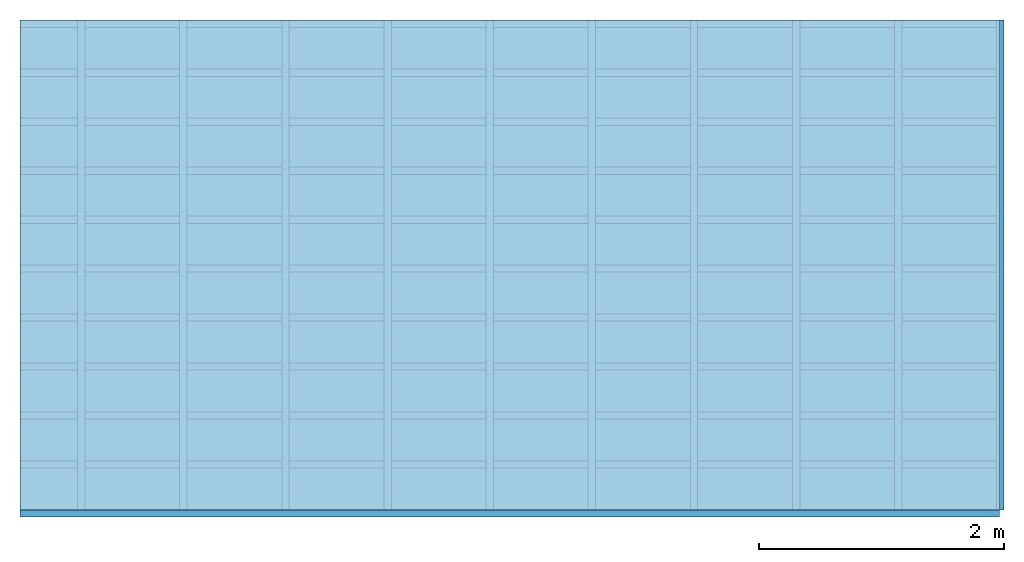
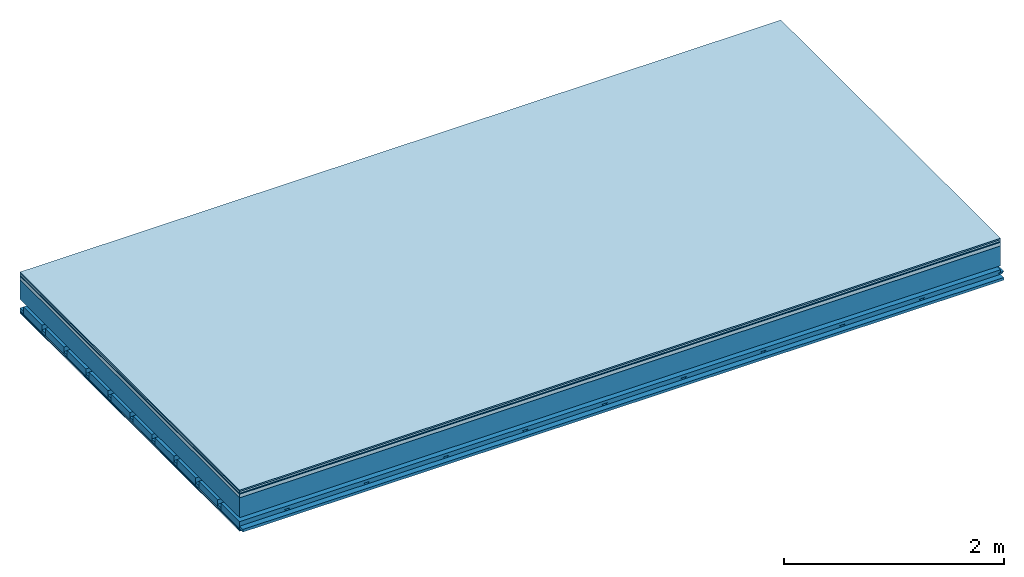
# One storey: 7 plates, 4 members, 1 element without a shape of its own.
"""IFC4 building model written with IfcOpenShell, lengths in metres."""

from ifc_helpers import new_model, si_unit, derived_unit, direction, frame, frame_2d, origin, origin_with_axes, place, context, project, spatial, polyline, rectangle, outline, extrude, material, layer, layer_set, type_object, element, aggregate, save


model = new_model("IFC4")

# Units and contexts
plan_context = context("Plan", 3, precision=1e-05, world=origin(), true_north=direction((0.0, 1.0)))
model_context = context("Model", 3, precision=1e-05, world=origin(), true_north=direction((0.0, 1.0)))
ifc_project = project(units=[si_unit("LENGTHUNIT", "METRE"), derived_unit("SOUNDPRESSUREUNIT", [(si_unit("PRESSUREUNIT", "PASCAL", prefix="MICRO"), 0)]), si_unit("ENERGYUNIT", "JOULE", prefix="MEGA"), si_unit("MASSUNIT", "GRAM", prefix="KILO"), derived_unit("THERMALTRANSMITTANCEUNIT", [(si_unit("POWERUNIT", "WATT"), 1), (si_unit("AREAUNIT", "SQUARE_METRE"), -1), (si_unit("THERMODYNAMICTEMPERATUREUNIT", "KELVIN"), -1)]), derived_unit("AREADENSITYUNIT", [(si_unit("MASSUNIT", "GRAM", prefix="KILO"), 1), (si_unit("AREAUNIT", "SQUARE_METRE"), -1)]), derived_unit("USERDEFINED", [(si_unit("ENERGYUNIT", "JOULE", prefix="MEGA"), 1), (si_unit("AREAUNIT", "SQUARE_METRE"), -1)])], contexts=[plan_context, model_context])

# Site, building, storey
site = spatial("IfcSite", under=ifc_project)
building_placement = place(None, origin())
building = spatial("IfcBuilding", under=site, at=building_placement)
storey_placement = place(building_placement, origin())
storey = spatial("IfcBuildingStorey", under=building, at=storey_placement)

# Slab, members, plates
ifc_material_1 = material(Category="11.013")
ifc_layer_1 = layer(ifc_material_1, 0.015, Name="Flooring")
ifc_material_2 = material(Category="03.007")
ifc_layer_2 = layer(ifc_material_2, 0.02, Name="On-material")
ifc_material_3 = material(Name="Wood fiber generic product", Category="10.009")
ifc_layer_3 = layer(ifc_material_3, 0.01, Name="Impact sound insulation")
ifc_material_4 = material(Name="Concrete panels", Category="02.007")
ifc_layer_4 = layer(ifc_material_4, 0.04, Name="on Supporting structure")
ifc_material_5 = material(Name="no composite action")
ifc_layer_5 = layer(ifc_material_5, 0.0, Name="Bond")
ifc_layer_6 = layer(None, 0.22, Name="Supporting structure")
ifc_layer_7 = layer(ifc_material_5, 0.0, Name="Bond")
ifc_layer_8 = layer(None, 0.095, Name="Coupling")
ifc_layer_9 = layer(None, 0.03, Name="Battens / profiles")
ifc_material_6 = material(Name="Plasterboard type A", Category="03.008")
ifc_layer_10 = layer(ifc_material_6, 0.0125, Name="Ceiling covering 1st layer")
ifc_layer_11 = layer(ifc_material_6, 0.0125, Name="Ceiling covering layer 2")
ifc_material_7 = material(Category="04.001")
ifc_layer_12 = layer(ifc_material_7, 0.003, Name="Surface / treatment")
ifc_layer_set = layer_set([ifc_layer_1, ifc_layer_2, ifc_layer_3, ifc_layer_4, ifc_layer_5, ifc_layer_6, ifc_layer_7, ifc_layer_8, ifc_layer_9, ifc_layer_10, ifc_layer_11, ifc_layer_12])
slab_type = type_object("IfcSlabType", Name="A2137", PredefinedType="NOTDEFINED", material=ifc_layer_set)
slab_placement = place(None, frame((0.0, 0.0, 0.0), z_axis=(0.0, 0.0, -1.0), x_axis=(1.0, 0.0, 0.0)))
slab = element("IfcSlab", 1, at=slab_placement, inside=storey, type_object=slab_type, material=ifc_layer_set, Name="Slab #1")
ifc_material_8 = material(Name="Solid timber panel")
member_1_placement = place(slab_placement, origin())
member_1 = element("IfcMember", 2, at=member_1_placement, material=ifc_material_8, Name="Supporting structure", context=plan_context, shape_type="SweptSolid", body=[
    extrude(rectangle(XDim=1.0, YDim=0.22, at=frame_2d((0.5, 0.11), x_axis=(1.0, 0.0))), frame((0.0, 4.0, 0.085), z_axis=(0.0, -1.0, 0.0), x_axis=(1.0, 0.0, 0.0)), (0.0, 0.0, 1.0), 4.0),
    extrude(rectangle(XDim=1.0, YDim=0.22, at=frame_2d((0.5, 0.11), x_axis=(1.0, 0.0))), frame((1.0, 4.0, 0.085), z_axis=(0.0, -1.0, 0.0), x_axis=(1.0, 0.0, 0.0)), (0.0, 0.0, 1.0), 4.0),
    extrude(rectangle(XDim=1.0, YDim=0.22, at=frame_2d((0.5, 0.11), x_axis=(1.0, 0.0))), frame((2.0, 4.0, 0.085), z_axis=(0.0, -1.0, 0.0), x_axis=(1.0, 0.0, 0.0)), (0.0, 0.0, 1.0), 4.0),
    extrude(rectangle(XDim=1.0, YDim=0.22, at=frame_2d((0.5, 0.11), x_axis=(1.0, 0.0))), frame((3.0, 4.0, 0.085), z_axis=(0.0, -1.0, 0.0), x_axis=(1.0, 0.0, 0.0)), (0.0, 0.0, 1.0), 4.0),
    extrude(rectangle(XDim=1.0, YDim=0.22, at=frame_2d((0.5, 0.11), x_axis=(1.0, 0.0))), frame((4.0, 4.0, 0.085), z_axis=(0.0, -1.0, 0.0), x_axis=(1.0, 0.0, 0.0)), (0.0, 0.0, 1.0), 4.0),
    extrude(rectangle(XDim=1.0, YDim=0.22, at=frame_2d((0.5, 0.11), x_axis=(1.0, 0.0))), frame((5.0, 4.0, 0.085), z_axis=(0.0, -1.0, 0.0), x_axis=(1.0, 0.0, 0.0)), (0.0, 0.0, 1.0), 4.0),
    extrude(rectangle(XDim=1.0, YDim=0.22, at=frame_2d((0.5, 0.11), x_axis=(1.0, 0.0))), frame((6.0, 4.0, 0.085), z_axis=(0.0, -1.0, 0.0), x_axis=(1.0, 0.0, 0.0)), (0.0, 0.0, 1.0), 4.0),
    extrude(rectangle(XDim=1.0, YDim=0.22, at=frame_2d((0.5, 0.11), x_axis=(1.0, 0.0))), frame((7.0, 4.0, 0.085), z_axis=(0.0, -1.0, 0.0), x_axis=(1.0, 0.0, 0.0)), (0.0, 0.0, 1.0), 4.0),
])
ifc_material_9 = material()
member_2_placement = place(slab_placement, origin())
member_2 = element("IfcMember", 3, at=member_2_placement, material=ifc_material_9, Name="Coupling", context=plan_context, shape_type="SweptSolid", body=[
    extrude(outline(polyline([(0.0, 0.0), (0.06, 0.0), (0.04, 0.02), (0.02, 0.02), (0.0, 0.0)])), frame((0.47, 4.0, 0.38), z_axis=(0.0, -1.0, 0.0), x_axis=(1.0, 0.0, 0.0)), (0.0, 0.0, 1.0), 4.0),
    extrude(outline(polyline([(0.0, 0.0), (0.06, 0.0), (0.04, 0.02), (0.02, 0.02), (0.0, 0.0)])), frame((1.304, 4.0, 0.38), z_axis=(0.0, -1.0, 0.0), x_axis=(1.0, 0.0, 0.0)), (0.0, 0.0, 1.0), 4.0),
    extrude(outline(polyline([(0.0, 0.0), (0.06, 0.0), (0.04, 0.02), (0.02, 0.02), (0.0, 0.0)])), frame((2.138, 4.0, 0.38), z_axis=(0.0, -1.0, 0.0), x_axis=(1.0, 0.0, 0.0)), (0.0, 0.0, 1.0), 4.0),
    extrude(outline(polyline([(0.0, 0.0), (0.06, 0.0), (0.04, 0.02), (0.02, 0.02), (0.0, 0.0)])), frame((2.972, 4.0, 0.38), z_axis=(0.0, -1.0, 0.0), x_axis=(1.0, 0.0, 0.0)), (0.0, 0.0, 1.0), 4.0),
    extrude(outline(polyline([(0.0, 0.0), (0.06, 0.0), (0.04, 0.02), (0.02, 0.02), (0.0, 0.0)])), frame((3.806, 4.0, 0.38), z_axis=(0.0, -1.0, 0.0), x_axis=(1.0, 0.0, 0.0)), (0.0, 0.0, 1.0), 4.0),
    extrude(outline(polyline([(0.0, 0.0), (0.06, 0.0), (0.04, 0.02), (0.02, 0.02), (0.0, 0.0)])), frame((4.64, 4.0, 0.38), z_axis=(0.0, -1.0, 0.0), x_axis=(1.0, 0.0, 0.0)), (0.0, 0.0, 1.0), 4.0),
    extrude(outline(polyline([(0.0, 0.0), (0.06, 0.0), (0.04, 0.02), (0.02, 0.02), (0.0, 0.0)])), frame((5.474, 4.0, 0.38), z_axis=(0.0, -1.0, 0.0), x_axis=(1.0, 0.0, 0.0)), (0.0, 0.0, 1.0), 4.0),
    extrude(outline(polyline([(0.0, 0.0), (0.06, 0.0), (0.04, 0.02), (0.02, 0.02), (0.0, 0.0)])), frame((6.308, 4.0, 0.38), z_axis=(0.0, -1.0, 0.0), x_axis=(1.0, 0.0, 0.0)), (0.0, 0.0, 1.0), 4.0),
    extrude(outline(polyline([(0.0, 0.0), (0.06, 0.0), (0.04, 0.02), (0.02, 0.02), (0.0, 0.0)])), frame((7.142, 4.0, 0.38), z_axis=(0.0, -1.0, 0.0), x_axis=(1.0, 0.0, 0.0)), (0.0, 0.0, 1.0), 4.0),
    extrude(outline(polyline([(0.0, 0.0), (0.06, 0.0), (0.04, 0.02), (0.02, 0.02), (0.0, 0.0)])), frame((7.976, 4.0, 0.38), z_axis=(0.0, -1.0, 0.0), x_axis=(1.0, 0.0, 0.0)), (0.0, 0.0, 1.0), 4.0),
])
member_3_placement = place(slab_placement, origin())
member_3 = element("IfcMember", 4, at=member_3_placement, material=ifc_material_9, Name="Battens / profiles", context=plan_context, shape_type="SweptSolid", body=[
    extrude(rectangle(XDim=0.06, YDim=0.03, at=frame_2d((0.03, 0.015), x_axis=(1.0, 0.0))), frame((0.0, 0.0, 0.4), z_axis=(1.0, 0.0, 0.0), x_axis=(0.0, 1.0, 0.0)), (0.0, 0.0, 1.0), 8.0),
    extrude(rectangle(XDim=0.06, YDim=0.03, at=frame_2d((0.03, 0.015), x_axis=(1.0, 0.0))), frame((0.0, 0.4, 0.4), z_axis=(1.0, 0.0, 0.0), x_axis=(0.0, 1.0, 0.0)), (0.0, 0.0, 1.0), 8.0),
    extrude(rectangle(XDim=0.06, YDim=0.03, at=frame_2d((0.03, 0.015), x_axis=(1.0, 0.0))), frame((0.0, 0.8, 0.4), z_axis=(1.0, 0.0, 0.0), x_axis=(0.0, 1.0, 0.0)), (0.0, 0.0, 1.0), 8.0),
    extrude(rectangle(XDim=0.06, YDim=0.03, at=frame_2d((0.03, 0.015), x_axis=(1.0, 0.0))), frame((0.0, 1.2, 0.4), z_axis=(1.0, 0.0, 0.0), x_axis=(0.0, 1.0, 0.0)), (0.0, 0.0, 1.0), 8.0),
    extrude(rectangle(XDim=0.06, YDim=0.03, at=frame_2d((0.03, 0.015), x_axis=(1.0, 0.0))), frame((0.0, 1.6, 0.4), z_axis=(1.0, 0.0, 0.0), x_axis=(0.0, 1.0, 0.0)), (0.0, 0.0, 1.0), 8.0),
    extrude(rectangle(XDim=0.06, YDim=0.03, at=frame_2d((0.03, 0.015), x_axis=(1.0, 0.0))), frame((0.0, 2.0, 0.4), z_axis=(1.0, 0.0, 0.0), x_axis=(0.0, 1.0, 0.0)), (0.0, 0.0, 1.0), 8.0),
    extrude(rectangle(XDim=0.06, YDim=0.03, at=frame_2d((0.03, 0.015), x_axis=(1.0, 0.0))), frame((0.0, 2.4, 0.4), z_axis=(1.0, 0.0, 0.0), x_axis=(0.0, 1.0, 0.0)), (0.0, 0.0, 1.0), 8.0),
    extrude(rectangle(XDim=0.06, YDim=0.03, at=frame_2d((0.03, 0.015), x_axis=(1.0, 0.0))), frame((0.0, 2.8, 0.4), z_axis=(1.0, 0.0, 0.0), x_axis=(0.0, 1.0, 0.0)), (0.0, 0.0, 1.0), 8.0),
    extrude(rectangle(XDim=0.06, YDim=0.03, at=frame_2d((0.03, 0.015), x_axis=(1.0, 0.0))), frame((0.0, 3.2, 0.4), z_axis=(1.0, 0.0, 0.0), x_axis=(0.0, 1.0, 0.0)), (0.0, 0.0, 1.0), 8.0),
    extrude(rectangle(XDim=0.06, YDim=0.03, at=frame_2d((0.03, 0.015), x_axis=(1.0, 0.0))), frame((0.0, 3.6, 0.4), z_axis=(1.0, 0.0, 0.0), x_axis=(0.0, 1.0, 0.0)), (0.0, 0.0, 1.0), 8.0),
    extrude(rectangle(XDim=0.06, YDim=0.03, at=frame_2d((0.03, 0.015), x_axis=(1.0, 0.0))), frame((0.0, 4.0, 0.4), z_axis=(1.0, 0.0, 0.0), x_axis=(0.0, 1.0, 0.0)), (0.0, 0.0, 1.0), 8.0),
])
ifc_material_10 = material()
member_4_placement = place(slab_placement, origin())
member_4 = element("IfcMember", 5, at=member_4_placement, material=ifc_material_10, Name="Cavity", context=plan_context, shape_type="SweptSolid", body=[
    extrude(rectangle(XDim=0.34, YDim=0.08, at=frame_2d((0.17, 0.04), x_axis=(1.0, 0.0))), frame((0.0, 0.06, 0.35), z_axis=(1.0, 0.0, 0.0), x_axis=(0.0, 1.0, 0.0)), (0.0, 0.0, 1.0), 8.0),
    extrude(rectangle(XDim=0.34, YDim=0.08, at=frame_2d((0.17, 0.04), x_axis=(1.0, 0.0))), frame((0.0, 0.46, 0.35), z_axis=(1.0, 0.0, 0.0), x_axis=(0.0, 1.0, 0.0)), (0.0, 0.0, 1.0), 8.0),
    extrude(rectangle(XDim=0.34, YDim=0.08, at=frame_2d((0.17, 0.04), x_axis=(1.0, 0.0))), frame((0.0, 0.86, 0.35), z_axis=(1.0, 0.0, 0.0), x_axis=(0.0, 1.0, 0.0)), (0.0, 0.0, 1.0), 8.0),
    extrude(rectangle(XDim=0.34, YDim=0.08, at=frame_2d((0.17, 0.04), x_axis=(1.0, 0.0))), frame((0.0, 1.26, 0.35), z_axis=(1.0, 0.0, 0.0), x_axis=(0.0, 1.0, 0.0)), (0.0, 0.0, 1.0), 8.0),
    extrude(rectangle(XDim=0.34, YDim=0.08, at=frame_2d((0.17, 0.04), x_axis=(1.0, 0.0))), frame((0.0, 1.66, 0.35), z_axis=(1.0, 0.0, 0.0), x_axis=(0.0, 1.0, 0.0)), (0.0, 0.0, 1.0), 8.0),
    extrude(rectangle(XDim=0.34, YDim=0.08, at=frame_2d((0.17, 0.04), x_axis=(1.0, 0.0))), frame((0.0, 2.06, 0.35), z_axis=(1.0, 0.0, 0.0), x_axis=(0.0, 1.0, 0.0)), (0.0, 0.0, 1.0), 8.0),
    extrude(rectangle(XDim=0.34, YDim=0.08, at=frame_2d((0.17, 0.04), x_axis=(1.0, 0.0))), frame((0.0, 2.46, 0.35), z_axis=(1.0, 0.0, 0.0), x_axis=(0.0, 1.0, 0.0)), (0.0, 0.0, 1.0), 8.0),
    extrude(rectangle(XDim=0.34, YDim=0.08, at=frame_2d((0.17, 0.04), x_axis=(1.0, 0.0))), frame((0.0, 2.86, 0.35), z_axis=(1.0, 0.0, 0.0), x_axis=(0.0, 1.0, 0.0)), (0.0, 0.0, 1.0), 8.0),
    extrude(rectangle(XDim=0.34, YDim=0.08, at=frame_2d((0.17, 0.04), x_axis=(1.0, 0.0))), frame((0.0, 3.26, 0.35), z_axis=(1.0, 0.0, 0.0), x_axis=(0.0, 1.0, 0.0)), (0.0, 0.0, 1.0), 8.0),
    extrude(rectangle(XDim=0.34, YDim=0.08, at=frame_2d((0.17, 0.04), x_axis=(1.0, 0.0))), frame((0.0, 3.66, 0.35), z_axis=(1.0, 0.0, 0.0), x_axis=(0.0, 1.0, 0.0)), (0.0, 0.0, 1.0), 8.0),
])
plate_1_placement = place(slab_placement, origin())
plate_1 = element("IfcPlate", 6, at=plate_1_placement, material=ifc_material_1, Name="Flooring", context=plan_context, shape_type="SweptSolid", body=[
    extrude(rectangle(XDim=8.0, YDim=4.0, at=frame_2d((4.0, 2.0), x_axis=(1.0, 0.0))), origin_with_axes(), (0.0, 0.0, 1.0), 0.015),
])
plate_2_placement = place(slab_placement, origin())
plate_2 = element("IfcPlate", 7, at=plate_2_placement, material=ifc_material_2, Name="On-material", context=plan_context, shape_type="SweptSolid", body=[
    extrude(rectangle(XDim=8.0, YDim=4.0, at=frame_2d((4.0, 2.0), x_axis=(1.0, 0.0))), frame((0.0, 0.0, 0.015), z_axis=(0.0, 0.0, 1.0), x_axis=(1.0, 0.0, 0.0)), (0.0, 0.0, 1.0), 0.02),
])
plate_3_placement = place(slab_placement, origin())
plate_3 = element("IfcPlate", 8, at=plate_3_placement, material=ifc_material_3, Name="Impact sound insulation", context=plan_context, shape_type="SweptSolid", body=[
    extrude(rectangle(XDim=8.0, YDim=4.0, at=frame_2d((4.0, 2.0), x_axis=(1.0, 0.0))), frame((0.0, 0.0, 0.035), z_axis=(0.0, 0.0, 1.0), x_axis=(1.0, 0.0, 0.0)), (0.0, 0.0, 1.0), 0.01),
])
plate_4_placement = place(slab_placement, origin())
plate_4 = element("IfcPlate", 9, at=plate_4_placement, material=ifc_material_4, Name="on Supporting structure", context=plan_context, shape_type="SweptSolid", body=[
    extrude(rectangle(XDim=8.0, YDim=4.0, at=frame_2d((4.0, 2.0), x_axis=(1.0, 0.0))), frame((0.0, 0.0, 0.045), z_axis=(0.0, 0.0, 1.0), x_axis=(1.0, 0.0, 0.0)), (0.0, 0.0, 1.0), 0.04),
])
plate_5_placement = place(slab_placement, origin())
plate_5 = element("IfcPlate", 10, at=plate_5_placement, material=ifc_material_6, Name="Ceiling covering 1st layer", context=plan_context, shape_type="SweptSolid", body=[
    extrude(rectangle(XDim=8.0, YDim=4.0, at=frame_2d((4.0, 2.0), x_axis=(1.0, 0.0))), frame((0.0, 0.0, 0.43), z_axis=(0.0, 0.0, 1.0), x_axis=(1.0, 0.0, 0.0)), (0.0, 0.0, 1.0), 0.0125),
])
plate_6_placement = place(slab_placement, origin())
plate_6 = element("IfcPlate", 11, at=plate_6_placement, material=ifc_material_6, Name="Ceiling covering layer 2", context=plan_context, shape_type="SweptSolid", body=[
    extrude(rectangle(XDim=8.0, YDim=4.0, at=frame_2d((4.0, 2.0), x_axis=(1.0, 0.0))), frame((0.0, 0.0, 0.4425), z_axis=(0.0, 0.0, 1.0), x_axis=(1.0, 0.0, 0.0)), (0.0, 0.0, 1.0), 0.0125),
])
plate_7_placement = place(slab_placement, origin())
plate_7 = element("IfcPlate", 12, at=plate_7_placement, material=ifc_material_7, Name="Surface / treatment", context=plan_context, shape_type="SweptSolid", body=[
    extrude(rectangle(XDim=8.0, YDim=4.0, at=frame_2d((4.0, 2.0), x_axis=(1.0, 0.0))), frame((0.0, 0.0, 0.455), z_axis=(0.0, 0.0, 1.0), x_axis=(1.0, 0.0, 0.0)), (0.0, 0.0, 1.0), 0.003),
])
aggregate(slab, [plate_1, plate_2, plate_3, plate_4, member_1, member_2, member_3, member_4, plate_5, plate_6, plate_7])

save(model, "model.ifc")
